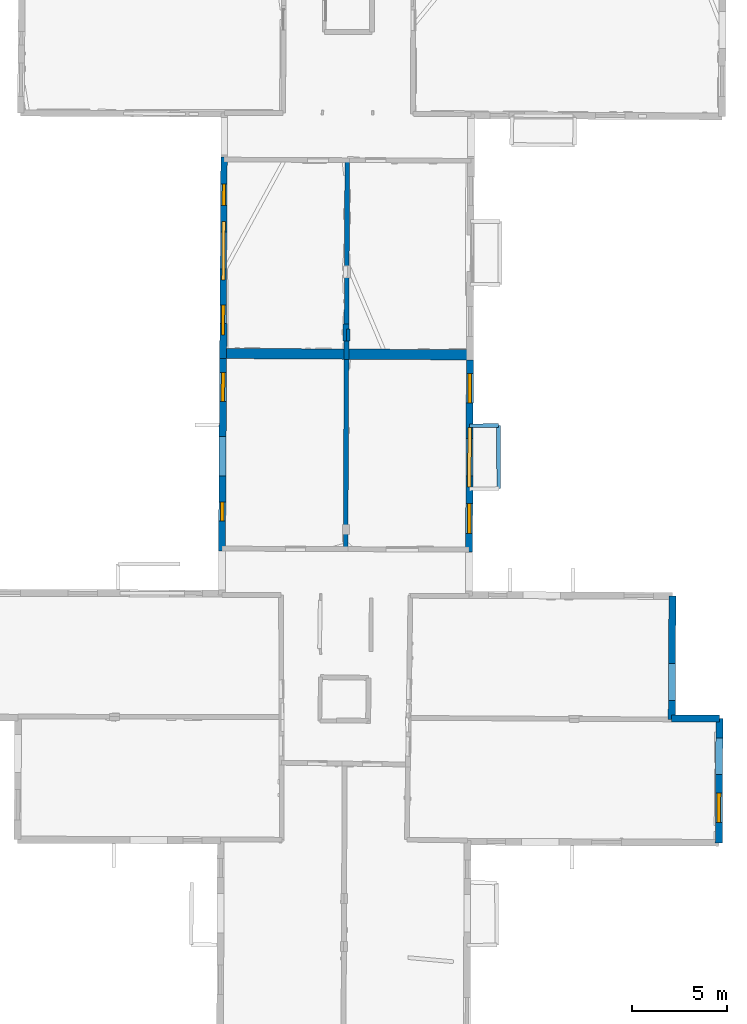
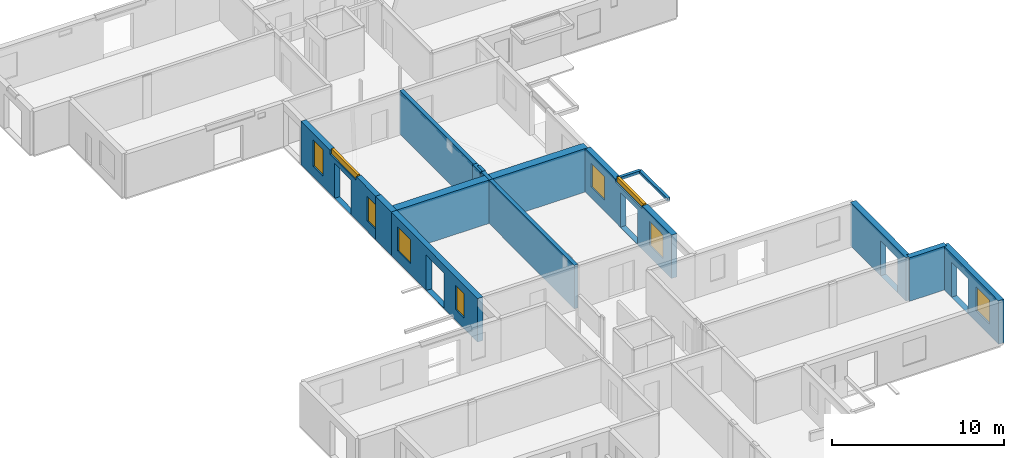
# One storey, part 6 of 15: 15 walls, 9 windows, 14 openings.
"""IFC2X3 building model written with IfcOpenShell, lengths in metres."""

from ifc_helpers import new_model, entity, si_unit, converted_unit, derived_unit, direction, frame, frame_2d, origin, origin_2d_with_axis, place, context, subcontext, project, spatial, polyline, rectangle, outline, extrude, source, transform, mapped, material, layer, layer_set, layer_usage, type_object, type_shapes, element, fill, save


model = new_model("IFC2X3")

# Units and contexts
model_context = context("Model", 3, precision=1e-05, world=origin(), true_north=direction((0.0, 1.0)))
body_context = subcontext(model_context, "Body", "Model", "MODEL_VIEW")
ifc_project = project(units=[si_unit("LENGTHUNIT", "METRE"), si_unit("AREAUNIT", "SQUARE_METRE"), si_unit("VOLUMEUNIT", "CUBIC_METRE"), converted_unit("PLANEANGLEUNIT", "DEGREE", entity("IfcRatioMeasure", 0.0174532925199433), si_unit("PLANEANGLEUNIT", "RADIAN"), dimensions=[0, 0, 0, 0, 0, 0, 0]), si_unit("MASSUNIT", "GRAM", prefix="KILO"), derived_unit("MASSDENSITYUNIT", [(si_unit("MASSUNIT", "GRAM", prefix="KILO"), 1), (si_unit("LENGTHUNIT", "METRE"), -3)]), derived_unit("MOMENTOFINERTIAUNIT", [(si_unit("LENGTHUNIT", "METRE"), 4)]), si_unit("TIMEUNIT", "SECOND"), si_unit("FREQUENCYUNIT", "HERTZ"), si_unit("THERMODYNAMICTEMPERATUREUNIT", "DEGREE_CELSIUS"), derived_unit("THERMALTRANSMITTANCEUNIT", [(si_unit("MASSUNIT", "GRAM", prefix="KILO"), 1), (si_unit("THERMODYNAMICTEMPERATUREUNIT", "KELVIN"), -1), (si_unit("TIMEUNIT", "SECOND"), -3)]), derived_unit("VOLUMETRICFLOWRATEUNIT", [(si_unit("LENGTHUNIT", "METRE"), 3), (si_unit("TIMEUNIT", "SECOND"), -1)]), si_unit("ELECTRICCURRENTUNIT", "AMPERE"), si_unit("ELECTRICVOLTAGEUNIT", "VOLT"), si_unit("POWERUNIT", "WATT"), si_unit("FORCEUNIT", "NEWTON", prefix="KILO"), si_unit("ILLUMINANCEUNIT", "LUX"), si_unit("LUMINOUSFLUXUNIT", "LUMEN"), si_unit("LUMINOUSINTENSITYUNIT", "CANDELA"), derived_unit("USERDEFINED", [(si_unit("MASSUNIT", "GRAM", prefix="KILO"), -1), (si_unit("LENGTHUNIT", "METRE"), -2), (si_unit("TIMEUNIT", "SECOND"), 3), (si_unit("LUMINOUSFLUXUNIT", "LUMEN"), 1)]), derived_unit("LINEARVELOCITYUNIT", [(si_unit("LENGTHUNIT", "METRE"), 1), (si_unit("TIMEUNIT", "SECOND"), -1)]), si_unit("PRESSUREUNIT", "PASCAL"), derived_unit("USERDEFINED", [(si_unit("LENGTHUNIT", "METRE"), -2), (si_unit("MASSUNIT", "GRAM", prefix="KILO"), 1), (si_unit("TIMEUNIT", "SECOND"), -2)]), derived_unit("LINEARFORCEUNIT", [(si_unit("MASSUNIT", "GRAM", prefix="KILO"), 1), (si_unit("LENGTHUNIT", "METRE"), 1), (si_unit("TIMEUNIT", "SECOND"), -2), (si_unit("LENGTHUNIT", "METRE"), -1)]), derived_unit("PLANARFORCEUNIT", [(si_unit("MASSUNIT", "GRAM", prefix="KILO"), 1), (si_unit("LENGTHUNIT", "METRE"), 1), (si_unit("TIMEUNIT", "SECOND"), -2), (si_unit("LENGTHUNIT", "METRE"), -2)])], contexts=[model_context])

# Site, building, storey
placement_1 = place(None, origin())
site = spatial("IfcSite", under=ifc_project, at=placement_1, CompositionType="ELEMENT")
building = spatial("IfcBuilding", under=site, at=placement_1, CompositionType="ELEMENT")
storey_placement = place(placement_1, frame((0.0, 0.0, 2.3807327747345)))
storey = spatial("IfcBuildingStorey", under=building, at=storey_placement, Name="Level 2", CompositionType="ELEMENT", Elevation=2.3807327747345)

# Walls
ifc_material_1 = material(Name="Default wall")
ifc_layer_1 = layer(ifc_material_1, 0.25)
ifc_layer_set_1 = layer_set([ifc_layer_1], Name="wall_thickness_0.2500")
ifc_layer_usage_1 = layer_usage(ifc_layer_set_1, "AXIS2", "POSITIVE", -0.125)
wall_type_1 = type_object("IfcWallType", Name="wall_thickness_0.2500", PredefinedType="STANDARD", material=ifc_layer_set_1)
wall_1_placement = place(storey_placement, frame((6.3156768318917, 48.7543611342191, 0.0), z_axis=(0.0, 0.0, 1.0), x_axis=(-0.00418840502214472, -0.999991228593216, 0.0)))
element("IfcWallStandardCase", 1, at=wall_1_placement, inside=storey, type_object=wall_type_1, material=ifc_layer_usage_1, Name="Wall:763", ObjectType="Wall", context=body_context, shape_type="SweptSolid", body=[
    extrude(outline(polyline([(10.470390607145, -0.125), (10.470390607145, 0.125), (0.0, 0.125), (0.0, -0.125), (10.470390607145, -0.125)])), origin(), (0.0, 0.0, 1.0), 3.08589615821838),
])
wall_2_placement = place(storey_placement, frame((6.27182259528892, 38.2840623671293, 0.0), z_axis=(0.0, 0.0, 1.0), x_axis=(-0.00418836837011911, -0.999991228746731, 0.0)))
element("IfcWallStandardCase", 2, at=wall_2_placement, inside=storey, type_object=wall_type_1, material=ifc_layer_usage_1, Name="Wall:764", ObjectType="Wall", context=body_context, shape_type="SweptSolid", body=[
    extrude(outline(polyline([(9.98389608873726, -0.125), (9.98389608873726, 0.125), (0.0, 0.125), (0.0, -0.125), (9.98389608873726, -0.125)])), origin(), (0.0, 0.0, 1.0), 3.08589615821838),
])
ifc_layer_2 = layer(ifc_material_1, 0.2)
ifc_layer_set_2 = layer_set([ifc_layer_2], Name="wall_thickness_0.2000")
ifc_layer_usage_2 = layer_usage(ifc_layer_set_2, "AXIS2", "POSITIVE", -0.1)
wall_type_2 = type_object("IfcWallType", Name="wall_thickness_0.2000", PredefinedType="STANDARD", material=ifc_layer_set_2)
placement_2 = place(placement_1, frame((0.0, 0.0, 5.26399993896484)))
wall_3_placement = place(placement_2, frame((12.7504581010681, 34.7912910754824, 0.0), z_axis=(0.0, 0.0, 1.0), x_axis=(0.999992666141911, 0.0038298384290755, 0.0)))
element("IfcWallStandardCase", 3, at=wall_3_placement, inside=storey, type_object=wall_type_2, material=ifc_layer_usage_2, Name="Wall:726", ObjectType="Wall", context=body_context, shape_type="SweptSolid", body=[
    extrude(outline(polyline([(1.51000653468389, -0.1), (1.51000653468389, 0.1), (0.0, 0.1), (0.0, -0.1), (1.51000653468389, -0.1)])), origin(), (0.0, 0.0, 1.0), 0.202628993988037),
])
placement_3 = place(placement_1, frame((0.0, 0.0, 5.26399993896484)))
wall_4_placement = place(placement_3, frame((14.2604541777438, 34.7970756808288, 0.0), z_axis=(0.0, 0.0, 1.0), x_axis=(0.00704195733225615, -0.999975205111072, 0.0)))
element("IfcWallStandardCase", 4, at=wall_4_placement, inside=storey, type_object=wall_type_2, material=ifc_layer_usage_2, Name="Wall:737", ObjectType="Wall", context=body_context, shape_type="SweptSolid", body=[
    extrude(outline(polyline([(3.31445138311406, -0.1), (3.31445138311406, 0.1), (0.0, 0.1), (0.0, -0.1), (3.31445138311406, -0.1)])), origin(), (0.0, 0.0, 1.0), 0.202628993988037),
])

# Wall, openings, windows
ifc_layer_3 = layer(ifc_material_1, 0.340000003576279)
ifc_layer_set_3 = layer_set([ifc_layer_3], Name="wall_thickness_0.3400")
ifc_layer_usage_3 = layer_usage(ifc_layer_set_3, "AXIS2", "POSITIVE", -0.170000001788139)
wall_type_3 = type_object("IfcWallType", Name="wall_thickness_0.3400", PredefinedType="STANDARD", material=ifc_layer_set_3)
wall_5_placement = place(storey_placement, frame((-0.161745375972368, 48.9116534915909, 0.0), z_axis=(0.0, 0.0, 1.0), x_axis=(-0.00591294725127191, -0.999982518374598, 0.0)))
wall_5 = element("IfcWallStandardCase", 5, at=wall_5_placement, inside=storey, type_object=wall_type_3, material=ifc_layer_usage_3, Name="Wall:784", ObjectType="Wall", context=body_context, shape_type="SweptSolid", body=[
    extrude(outline(polyline([(8.7541889871596, -0.170000001788139), (8.7541889871596, 0.170000001788139), (0.0, 0.170000001788139), (0.0, -0.170000001788139), (8.7541889871596, -0.170000001788139)])), origin(), (0.0, 0.0, 1.0), 3.08589615821838),
])
opening_1_placement = place(wall_5_placement, frame((3.94108986341754, -0.170000001788139, 0.00526785850524902)))
element("IfcOpeningElement", 6, at=opening_1_placement, cuts=wall_5, Name="Opening : 1935 x 2465 : 494", ObjectType="Opening", context=body_context, shape_type="SweptSolid", body=[
    extrude(rectangle(XDim=1.935, YDim=2.465, at=frame_2d((1.2325, 0.9675), x_axis=(0.0, 1.0))), frame((0.0, 0.0, 0.0), z_axis=(0.0, 1.0, 0.0), x_axis=(0.0, 0.0, 1.0)), (0.0, 0.0, 1.0), 0.340000003576279),
])
opening_2_placement = place(wall_5_placement, frame((1.40608766182194, -0.170000001788139, 0.750267744064331)))
opening_2 = element("IfcOpeningElement", 7, at=opening_2_placement, cuts=wall_5, Name="Opening : 1145 x 1865 : 495", ObjectType="Opening", context=body_context, shape_type="SweptSolid", body=[
    extrude(rectangle(XDim=1.145, YDim=1.865, at=frame_2d((0.9325, 0.5725), x_axis=(0.0, 1.0))), frame((0.0, 0.0, 0.0), z_axis=(0.0, 1.0, 0.0), x_axis=(0.0, 0.0, 1.0)), (0.0, 0.0, 1.0), 0.340000003576279),
])
opening_3_placement = place(wall_5_placement, frame((3.39108864089171, -0.170000001788139, 2.81026768684387)))
opening_3 = element("IfcOpeningElement", 8, at=opening_3_placement, cuts=wall_5, Name="Opening : 3075 x 365 : 496", ObjectType="Opening", context=body_context, shape_type="SweptSolid", body=[
    extrude(rectangle(XDim=3.075, YDim=0.365, at=frame_2d((0.1825, 1.5375), x_axis=(0.0, 1.0))), frame((0.0, 0.0, 0.0), z_axis=(0.0, 1.0, 0.0), x_axis=(0.0, 0.0, 1.0)), (0.0, 0.0, 1.0), 0.340000003576279),
])
opening_4_placement = place(wall_5_placement, frame((7.76608882897656, -0.170000001788139, 0.720267772674561)))
opening_4 = element("IfcOpeningElement", 9, at=opening_4_placement, cuts=wall_5, Name="Opening : 1595 x 1750 : 497", ObjectType="Opening", context=body_context, shape_type="SweptSolid", body=[
    extrude(rectangle(XDim=1.595, YDim=1.75, at=frame_2d((0.875, 0.7975), x_axis=(0.0, 1.0))), frame((0.0, 0.0, 0.0), z_axis=(0.0, 1.0, 0.0), x_axis=(0.0, 0.0, 1.0)), (0.0, 0.0, 1.0), 0.340000003576279),
])
ifc_material_2 = material(Name="Window Default")
window_style_1 = type_object("IfcWindowStyle", Name="Window : 1145 x 1865mm", ConstructionType="NOTDEFINED", OperationType="NOTDEFINED", ParameterTakesPrecedence=False, Sizeable=False, material=ifc_material_2)
shared_shape_1 = source(origin(), body_context, "Body", "SweptSolid", [
    extrude(rectangle(XDim=0.170000001788139, YDim=1.145, at=origin_2d_with_axis()), frame((0.5725, 0.170000001788139, 0.0), z_axis=(0.0, 0.0, 1.0), x_axis=(0.0, 1.0, 0.0)), (0.0, 0.0, 1.0), 1.865),
])
type_shapes(window_style_1, [shared_shape_1])
window_1_placement = place(opening_2_placement, origin())
window_1 = element("IfcWindow", 10, at=window_1_placement, inside=storey, type_object=window_style_1, Name="Window : 1145 x 1865mm : 265", ObjectType="Window : 1145 x 1865mm", OverallHeight=1.865, OverallWidth=1.145, context=body_context, shape_type="MappedRepresentation", body=[
    mapped(shared_shape_1, transform((0.0, 0.0, 0.0), scale=1.0)),
])
fill(opening_2, window_1)
window_style_2 = type_object("IfcWindowStyle", Name="Window : 3075 x 365mm", ConstructionType="NOTDEFINED", OperationType="NOTDEFINED", ParameterTakesPrecedence=False, Sizeable=False, material=ifc_material_2)
shared_shape_2 = source(origin(), body_context, "Body", "SweptSolid", [
    extrude(rectangle(XDim=0.170000001788139, YDim=3.075, at=origin_2d_with_axis()), frame((1.5375, 0.170000001788139, 0.0), z_axis=(0.0, 0.0, 1.0), x_axis=(0.0, 1.0, 0.0)), (0.0, 0.0, 1.0), 0.365),
])
type_shapes(window_style_2, [shared_shape_2])
window_2_placement = place(opening_3_placement, origin())
window_2 = element("IfcWindow", 11, at=window_2_placement, inside=storey, type_object=window_style_2, Name="Window : 3075 x 365mm : 266", ObjectType="Window : 3075 x 365mm", OverallHeight=0.365, OverallWidth=3.075, context=body_context, shape_type="MappedRepresentation", body=[
    mapped(shared_shape_2, transform((0.0, 0.0, 0.0), scale=1.0)),
])
fill(opening_3, window_2)
window_style_3 = type_object("IfcWindowStyle", Name="Window : 1595 x 1750mm", ConstructionType="NOTDEFINED", OperationType="NOTDEFINED", ParameterTakesPrecedence=False, Sizeable=False, material=ifc_material_2)
shared_shape_3 = source(origin(), body_context, "Body", "SweptSolid", [
    extrude(rectangle(XDim=0.170000001788139, YDim=1.595, at=origin_2d_with_axis()), frame((0.7975, 0.170000001788139, 0.0), z_axis=(0.0, 0.0, 1.0), x_axis=(0.0, 1.0, 0.0)), (0.0, 0.0, 1.0), 1.75),
])
type_shapes(window_style_3, [shared_shape_3])
window_3_placement = place(opening_4_placement, origin())
window_3 = element("IfcWindow", 12, at=window_3_placement, inside=storey, type_object=window_style_3, Name="Window : 1595 x 1750mm : 267", ObjectType="Window : 1595 x 1750mm", OverallHeight=1.75, OverallWidth=1.595, context=body_context, shape_type="MappedRepresentation", body=[
    mapped(shared_shape_3, transform((0.0, 0.0, 0.0), scale=1.0)),
])
fill(opening_4, window_3)

# Wall, opening
ifc_layer_4 = layer(ifc_material_1, 0.370000004768372)
ifc_layer_set_4 = layer_set([ifc_layer_4], Name="wall_thickness_0.3700")
ifc_layer_usage_4 = layer_usage(ifc_layer_set_4, "AXIS2", "POSITIVE", -0.185000002384186)
wall_type_4 = type_object("IfcWallType", Name="wall_thickness_0.3700", PredefinedType="STANDARD", material=ifc_layer_set_4)
wall_6_placement = place(storey_placement, frame((23.4122642862826, 25.841536161951, 0.0), z_axis=(0.0, 0.0, 1.0), x_axis=(-0.00556036745275853, -0.999984541037405, 0.0)))
wall_6 = element("IfcWallStandardCase", 13, at=wall_6_placement, inside=storey, type_object=wall_type_4, material=ifc_layer_usage_4, Name="Wall:707", ObjectType="Wall", context=body_context, shape_type="SweptSolid", body=[
    extrude(outline(polyline([(6.49484756547081, -0.185000002384186), (6.49484756547081, 0.185000002384186), (0.0, 0.185000002384186), (0.0, -0.185000002384186), (6.49484756547081, -0.185000002384186)])), origin(), (0.0, 0.0, 1.0), 3.08589615821838),
])
opening_5_placement = place(wall_6_placement, frame((3.54695462286384, -0.185000002384186, 0.00526785850524902)))
element("IfcOpeningElement", 14, at=opening_5_placement, cuts=wall_6, Name="Opening : 1955 x 2465 : 448", ObjectType="Opening", context=body_context, shape_type="SweptSolid", body=[
    extrude(rectangle(XDim=1.955, YDim=2.465, at=frame_2d((1.2325, 0.9775), x_axis=(0.0, 1.0))), frame((0.0, 0.0, 0.0), z_axis=(0.0, 1.0, 0.0), x_axis=(0.0, 0.0, 1.0)), (0.0, 0.0, 1.0), 0.370000004768372),
])

# Wall, openings, window
wall_7_placement = place(storey_placement, frame((25.8828886507864, 19.4024328590418, 0.0), z_axis=(0.0, 0.0, 1.0), x_axis=(-0.00498765009158397, -0.999987561595925, 0.0)))
wall_7 = element("IfcWallStandardCase", 15, at=wall_7_placement, inside=storey, type_object=wall_type_4, material=ifc_layer_usage_4, Name="Wall:765", ObjectType="Wall", context=body_context, shape_type="SweptSolid", body=[
    extrude(outline(polyline([(6.54502045074674, -0.185000002384186), (6.54502045074674, 0.185000002384186), (0.0, 0.185000002384186), (0.0, -0.185000002384186), (6.54502045074674, -0.185000002384186)])), origin(), (0.0, 0.0, 1.0), 3.08589615821838),
])
opening_6_placement = place(wall_7_placement, frame((1.03396929571439, -0.185000002384186, 0.00526785850524902)))
element("IfcOpeningElement", 16, at=opening_6_placement, cuts=wall_7, Name="Opening : 1925 x 2480 : 484", ObjectType="Opening", context=body_context, shape_type="SweptSolid", body=[
    extrude(rectangle(XDim=1.925, YDim=2.48, at=frame_2d((1.24, 0.9625), x_axis=(0.0, 1.0))), frame((0.0, 0.0, 0.0), z_axis=(0.0, 1.0, 0.0), x_axis=(0.0, 0.0, 1.0)), (0.0, 0.0, 1.0), 0.370000004768372),
])
opening_7_placement = place(wall_7_placement, frame((3.92896951994931, -0.185000002384186, 0.790267705917358)))
opening_7 = element("IfcOpeningElement", 17, at=opening_7_placement, cuts=wall_7, Name="Opening : 1545 x 1695 : 485", ObjectType="Opening", context=body_context, shape_type="SweptSolid", body=[
    extrude(rectangle(XDim=1.545, YDim=1.695, at=frame_2d((0.8475, 0.7725), x_axis=(0.0, 1.0))), frame((0.0, 0.0, 0.0), z_axis=(0.0, 1.0, 0.0), x_axis=(0.0, 0.0, 1.0)), (0.0, 0.0, 1.0), 0.370000004768372),
])
window_style_4 = type_object("IfcWindowStyle", Name="Window : 1545 x 1695mm", ConstructionType="NOTDEFINED", OperationType="NOTDEFINED", ParameterTakesPrecedence=False, Sizeable=False, material=ifc_material_2)
shared_shape_4 = source(origin(), body_context, "Body", "SweptSolid", [
    extrude(rectangle(XDim=0.185000002384186, YDim=1.545, at=origin_2d_with_axis()), frame((0.7725, 0.185000002384186, 0.0), z_axis=(0.0, 0.0, 1.0), x_axis=(0.0, 1.0, 0.0)), (0.0, 0.0, 1.0), 1.695),
])
type_shapes(window_style_4, [shared_shape_4])
window_4_placement = place(opening_7_placement, origin())
window_4 = element("IfcWindow", 18, at=window_4_placement, inside=storey, type_object=window_style_4, Name="Window : 1545 x 1695mm : 261", ObjectType="Window : 1545 x 1695mm", OverallHeight=1.695, OverallWidth=1.545, context=body_context, shape_type="MappedRepresentation", body=[
    mapped(shared_shape_4, transform((0.0, 0.0, 0.0), scale=1.0)),
])
fill(opening_7, window_4)

# Wall
wall_8_placement = place(storey_placement, frame((-0.198508576094938, 40.1575288485552, 0.0), z_axis=(0.0, 0.0, 1.0), x_axis=(-0.00591293372574429, -0.999982518454575, 0.0)))
element("IfcWallStandardCase", 19, at=wall_8_placement, inside=storey, type_object=wall_type_4, material=ifc_layer_usage_4, Name="Wall:785", ObjectType="Wall", context=body_context, shape_type="SweptSolid", body=[
    extrude(outline(polyline([(1.83664099404172, -0.185000002384186), (1.83664099404172, 0.185000002384186), (0.0, 0.185000002384186), (0.0, -0.185000002384186), (1.83664099404172, -0.185000002384186)])), origin(), (0.0, 0.0, 1.0), 3.08589615821838),
])

# Wall, openings, windows
wall_9_placement = place(storey_placement, frame((-0.209368512570692, 38.3209199618365, 0.0), z_axis=(0.0, 0.0, 1.0), x_axis=(-0.00591293733645481, -0.999982518433225, 0.0)))
wall_9 = element("IfcWallStandardCase", 20, at=wall_9_placement, inside=storey, type_object=wall_type_4, material=ifc_layer_usage_4, Name="Wall:786", ObjectType="Wall", context=body_context, shape_type="SweptSolid", body=[
    extrude(outline(polyline([(10.1209769488449, -0.185000002384186), (10.1209769488449, 0.185000002384186), (0.0, 0.185000002384186), (0.0, -0.185000002384186), (10.1209769488449, -0.185000002384186)])), origin(), (0.0, 0.0, 1.0), 3.08589615821838),
])
opening_8_placement = place(wall_9_placement, frame((4.10435031508724, -0.185000002384186, 0.00526785850524902)))
element("IfcOpeningElement", 21, at=opening_8_placement, cuts=wall_9, Name="Opening : 2065 x 2510 : 498", ObjectType="Opening", context=body_context, shape_type="SweptSolid", body=[
    extrude(rectangle(XDim=2.065, YDim=2.51, at=frame_2d((1.255, 1.0325), x_axis=(0.0, 1.0))), frame((0.0, 0.0, 0.0), z_axis=(0.0, 1.0, 0.0), x_axis=(0.0, 0.0, 1.0)), (0.0, 0.0, 1.0), 0.370000004768372),
])
opening_9_placement = place(wall_9_placement, frame((0.725259108347929, -0.185000002384186, 0.770267724990845)))
opening_9 = element("IfcOpeningElement", 22, at=opening_9_placement, cuts=wall_9, Name="Opening : 1540 x 1700 : 499", ObjectType="Opening", context=body_context, shape_type="SweptSolid", body=[
    extrude(rectangle(XDim=1.54, YDim=1.7, at=frame_2d((0.85, 0.77), x_axis=(0.0, 1.0))), frame((0.0, 0.0, 0.0), z_axis=(0.0, 1.0, 0.0), x_axis=(0.0, 0.0, 1.0)), (0.0, 0.0, 1.0), 0.370000004768372),
])
opening_10_placement = place(wall_9_placement, frame((7.55063477419573, -0.185000002384186, 0.755267858505249)))
opening_10 = element("IfcOpeningElement", 23, at=opening_10_placement, cuts=wall_9, Name="Opening : 995 x 1730 : 500", ObjectType="Opening", context=body_context, shape_type="SweptSolid", body=[
    extrude(rectangle(XDim=0.995, YDim=1.73, at=frame_2d((0.865, 0.4975), x_axis=(0.0, 1.0))), frame((0.0, 0.0, 0.0), z_axis=(0.0, 1.0, 0.0), x_axis=(0.0, 0.0, 1.0)), (0.0, 0.0, 1.0), 0.370000004768372),
])
window_style_5 = type_object("IfcWindowStyle", Name="Window : 1540 x 1700mm", ConstructionType="NOTDEFINED", OperationType="NOTDEFINED", ParameterTakesPrecedence=False, Sizeable=False, material=ifc_material_2)
shared_shape_5 = source(origin(), body_context, "Body", "SweptSolid", [
    extrude(rectangle(XDim=0.185000002384186, YDim=1.54, at=origin_2d_with_axis()), frame((0.77, 0.185000002384186, 0.0), z_axis=(0.0, 0.0, 1.0), x_axis=(0.0, 1.0, 0.0)), (0.0, 0.0, 1.0), 1.7),
])
type_shapes(window_style_5, [shared_shape_5])
window_5_placement = place(opening_9_placement, origin())
window_5 = element("IfcWindow", 24, at=window_5_placement, inside=storey, type_object=window_style_5, Name="Window : 1540 x 1700mm : 268", ObjectType="Window : 1540 x 1700mm", OverallHeight=1.7, OverallWidth=1.54, context=body_context, shape_type="MappedRepresentation", body=[
    mapped(shared_shape_5, transform((0.0, 0.0, 0.0), scale=1.0)),
])
fill(opening_9, window_5)
window_style_6 = type_object("IfcWindowStyle", Name="Window : 995 x 1730mm", ConstructionType="NOTDEFINED", OperationType="NOTDEFINED", ParameterTakesPrecedence=False, Sizeable=False, material=ifc_material_2)
shared_shape_6 = source(origin(), body_context, "Body", "SweptSolid", [
    extrude(rectangle(XDim=0.185000002384186, YDim=0.995, at=origin_2d_with_axis()), frame((0.4975, 0.185000002384186, 0.0), z_axis=(0.0, 0.0, 1.0), x_axis=(0.0, 1.0, 0.0)), (0.0, 0.0, 1.0), 1.73),
])
type_shapes(window_style_6, [shared_shape_6])
window_6_placement = place(opening_10_placement, origin())
window_6 = element("IfcWindow", 25, at=window_6_placement, inside=storey, type_object=window_style_6, Name="Window : 995 x 1730mm : 269", ObjectType="Window : 995 x 1730mm", OverallHeight=1.73, OverallWidth=0.995, context=body_context, shape_type="MappedRepresentation", body=[
    mapped(shared_shape_6, transform((0.0, 0.0, 0.0), scale=1.0)),
])
fill(opening_10, window_6)

wall_10_placement = place(storey_placement, frame((12.7657836383905, 38.2475014984775, 0.0), z_axis=(0.0, 0.0, 1.0), x_axis=(-0.00443389533953228, -0.999990170237747, 0.0)))
wall_10 = element("IfcWallStandardCase", 26, at=wall_10_placement, inside=storey, type_object=wall_type_4, material=ifc_layer_usage_4, Name="Wall:799", ObjectType="Wall", context=body_context, shape_type="SweptSolid", body=[
    extrude(outline(polyline([(10.1071645518303, -0.185000002384186), (10.1071645518303, 0.185000002384186), (0.0, 0.185000002384186), (0.0, -0.185000002384186), (10.1071645518303, -0.185000002384186)])), origin(), (0.0, 0.0, 1.0), 3.08589615821838),
])
opening_11_placement = place(wall_10_placement, frame((4.11899802123229, -0.185000002384186, 0.00526785850524902)))
element("IfcOpeningElement", 27, at=opening_11_placement, cuts=wall_10, Name="Opening : 1985 x 2465 : 507", ObjectType="Opening", context=body_context, shape_type="SweptSolid", body=[
    extrude(rectangle(XDim=1.985, YDim=2.465, at=frame_2d((1.2325, 0.9925), x_axis=(0.0, 1.0))), frame((0.0, 0.0, 0.0), z_axis=(0.0, 1.0, 0.0), x_axis=(0.0, 0.0, 1.0)), (0.0, 0.0, 1.0), 0.370000004768372),
])
opening_12_placement = place(wall_10_placement, frame((0.698996750081038, -0.185000002384186, 0.78526759147644)))
opening_12 = element("IfcOpeningElement", 28, at=opening_12_placement, cuts=wall_10, Name="Opening : 1575 x 1685 : 508", ObjectType="Opening", context=body_context, shape_type="SweptSolid", body=[
    extrude(rectangle(XDim=1.575, YDim=1.685, at=frame_2d((0.8425, 0.7875), x_axis=(0.0, 1.0))), frame((0.0, 0.0, 0.0), z_axis=(0.0, 1.0, 0.0), x_axis=(0.0, 0.0, 1.0)), (0.0, 0.0, 1.0), 0.370000004768372),
])
opening_13_placement = place(wall_10_placement, frame((3.55471863811812, -0.185000002384186, 2.87026762962341)))
opening_13 = element("IfcOpeningElement", 29, at=opening_13_placement, cuts=wall_10, Name="Opening : 3120 x 305 : 509", ObjectType="Opening", context=body_context, shape_type="SweptSolid", body=[
    extrude(rectangle(XDim=3.12, YDim=0.305, at=frame_2d((0.1525, 1.56), x_axis=(0.0, 1.0))), frame((0.0, 0.0, 0.0), z_axis=(0.0, 1.0, 0.0), x_axis=(0.0, 0.0, 1.0)), (0.0, 0.0, 1.0), 0.370000004768372),
])
opening_14_placement = place(wall_10_placement, frame((7.54899771014626, -0.185000002384186, 0.795267820358276)))
opening_14 = element("IfcOpeningElement", 30, at=opening_14_placement, cuts=wall_10, Name="Opening : 1575 x 1700 : 510", ObjectType="Opening", context=body_context, shape_type="SweptSolid", body=[
    extrude(rectangle(XDim=1.575, YDim=1.7, at=frame_2d((0.85, 0.7875), x_axis=(0.0, 1.0))), frame((0.0, 0.0, 0.0), z_axis=(0.0, 1.0, 0.0), x_axis=(0.0, 0.0, 1.0)), (0.0, 0.0, 1.0), 0.370000004768372),
])
window_style_7 = type_object("IfcWindowStyle", Name="Window : 1575 x 1700mm", ConstructionType="NOTDEFINED", OperationType="NOTDEFINED", ParameterTakesPrecedence=False, Sizeable=False, material=ifc_material_2)
shared_shape_7 = source(origin(), body_context, "Body", "SweptSolid", [
    extrude(rectangle(XDim=0.189999997615814, YDim=1.575, at=origin_2d_with_axis()), frame((0.7875, 0.189999997615814, 0.0), z_axis=(0.0, 0.0, 1.0), x_axis=(0.0, 1.0, 0.0)), (0.0, 0.0, 1.0), 1.7),
])
type_shapes(window_style_7, [shared_shape_7])
window_7_placement = place(opening_14_placement, origin())
window_7 = element("IfcWindow", 31, at=window_7_placement, inside=storey, type_object=window_style_7, Name="Window : 1575 x 1700mm : 275", ObjectType="Window : 1575 x 1700mm", OverallHeight=1.7, OverallWidth=1.575, context=body_context, shape_type="MappedRepresentation", body=[
    mapped(shared_shape_7, transform((0.0, 0.0, 0.0), scale=1.0)),
])
fill(opening_14, window_7)
window_style_8 = type_object("IfcWindowStyle", Name="Window : 1575 x 1685mm", ConstructionType="NOTDEFINED", OperationType="NOTDEFINED", ParameterTakesPrecedence=False, Sizeable=False, material=ifc_material_2)
shared_shape_8 = source(origin(), body_context, "Body", "SweptSolid", [
    extrude(rectangle(XDim=0.185000002384186, YDim=1.575, at=origin_2d_with_axis()), frame((0.7875, 0.185000002384186, 0.0), z_axis=(0.0, 0.0, 1.0), x_axis=(0.0, 1.0, 0.0)), (0.0, 0.0, 1.0), 1.685),
])
type_shapes(window_style_8, [shared_shape_8])
window_8_placement = place(opening_12_placement, origin())
window_8 = element("IfcWindow", 32, at=window_8_placement, inside=storey, type_object=window_style_8, Name="Window : 1575 x 1685mm : 273", ObjectType="Window : 1575 x 1685mm", OverallHeight=1.685, OverallWidth=1.575, context=body_context, shape_type="MappedRepresentation", body=[
    mapped(shared_shape_8, transform((0.0, 0.0, 0.0), scale=1.0)),
])
fill(opening_12, window_8)
window_style_9 = type_object("IfcWindowStyle", Name="Window : 3120 x 305mm", ConstructionType="NOTDEFINED", OperationType="NOTDEFINED", ParameterTakesPrecedence=False, Sizeable=False, material=ifc_material_2)
shared_shape_9 = source(origin(), body_context, "Body", "SweptSolid", [
    extrude(rectangle(XDim=0.185000002384186, YDim=3.12, at=origin_2d_with_axis()), frame((1.56, 0.185000002384186, 0.0), z_axis=(0.0, 0.0, 1.0), x_axis=(0.0, 1.0, 0.0)), (0.0, 0.0, 1.0), 0.305),
])
type_shapes(window_style_9, [shared_shape_9])
window_9_placement = place(opening_13_placement, origin())
window_9 = element("IfcWindow", 33, at=window_9_placement, inside=storey, type_object=window_style_9, Name="Window : 3120 x 305mm : 274", ObjectType="Window : 3120 x 305mm", OverallHeight=0.305, OverallWidth=3.12, context=body_context, shape_type="MappedRepresentation", body=[
    mapped(shared_shape_9, transform((0.0, 0.0, 0.0), scale=1.0)),
])
fill(opening_13, window_9)

# Walls
wall_11_placement = place(storey_placement, frame((23.3764713345489, 19.4047236618304, 0.0), z_axis=(0.0, 0.0, 1.0), x_axis=(0.999999581658364, -0.000914703830003024, 0.0)))
element("IfcWallStandardCase", 34, at=wall_11_placement, inside=storey, type_object=wall_type_4, material=ifc_layer_usage_4, Name="Wall:810", ObjectType="Wall", context=body_context, shape_type="SweptSolid", body=[
    extrude(outline(polyline([(2.50642118403838, -0.185000002384186), (2.50642118403838, 0.185000002384186), (0.0, 0.185000002384186), (0.0, -0.185000002384186), (2.50642118403838, -0.185000002384186)])), origin(), (0.0, 0.0, 1.0), 3.08589615821838),
])
ifc_layer_5 = layer(ifc_material_1, 0.200000002980232)
ifc_layer_set_5 = layer_set([ifc_layer_5], Name="wall_thickness_0.2000")
ifc_layer_usage_5 = layer_usage(ifc_layer_set_5, "AXIS2", "POSITIVE", -0.100000001490116)
wall_type_5 = type_object("IfcWallType", Name="wall_thickness_0.2000", PredefinedType="STANDARD", material=ifc_layer_set_5)
wall_12_placement = place(storey_placement, frame((6.37025254338135, 39.8731516147445, 0.0), z_axis=(0.0, 0.0, 1.0), x_axis=(0.00318691649093974, -0.999994921768746, 0.0)))
element("IfcWallStandardCase", 35, at=wall_12_placement, inside=storey, type_object=wall_type_5, material=ifc_layer_usage_5, Name="Wall:774", ObjectType="Wall", context=body_context, shape_type="SweptSolid", body=[
    extrude(outline(polyline([(0.635001546217902, -0.100000001490116), (0.635001546217902, 0.100000001490116), (0.0, 0.100000001490116), (0.0, -0.100000001490116), (0.635001546217902, -0.100000001490116)])), origin(), (0.0, 0.0, 1.0), 3.08589615821838),
])
ifc_layer_6 = layer(ifc_material_1, 0.540000021457672)
ifc_layer_set_6 = layer_set([ifc_layer_6], Name="wall_thickness_0.5400")
ifc_layer_usage_6 = layer_usage(ifc_layer_set_6, "AXIS2", "POSITIVE", -0.270000010728836)
wall_type_6 = type_object("IfcWallType", Name="wall_thickness_0.5400", PredefinedType="STANDARD", material=ifc_layer_set_6)
wall_13_placement = place(storey_placement, frame((-0.207773928809177, 38.590914726472, 0.0), z_axis=(0.0, 0.0, 1.0), x_axis=(0.999983991525824, -0.00565832944255788, 0.0)))
element("IfcWallStandardCase", 36, at=wall_13_placement, inside=storey, type_object=wall_type_6, material=ifc_layer_usage_6, Name="Wall:780", ObjectType="Wall", context=body_context, shape_type="SweptSolid", body=[
    extrude(outline(polyline([(6.60622872622302, -0.270000010728836), (6.60622872622302, 0.270000010728836), (0.0, 0.270000010728836), (0.0, -0.270000010728836), (6.60622872622302, -0.270000010728836)])), origin(), (0.0, 0.0, 1.0), 3.08589615821838),
])
wall_14_placement = place(storey_placement, frame((6.39834904177188, 38.5535345079662, 0.0), z_axis=(0.0, 0.0, 1.0), x_axis=(0.999983990587147, -0.00565849533041731, 0.0)))
element("IfcWallStandardCase", 37, at=wall_14_placement, inside=storey, type_object=wall_type_6, material=ifc_layer_usage_6, Name="Wall:781", ObjectType="Wall", context=body_context, shape_type="SweptSolid", body=[
    extrude(outline(polyline([(6.36873284575136, -0.270000010728836), (6.36873284575136, 0.270000010728836), (0.0, 0.270000010728836), (0.0, -0.270000010728836), (6.36873284575136, -0.270000010728836)])), origin(), (0.0, 0.0, 1.0), 3.08589615821838),
])
ifc_layer_7 = layer(ifc_material_1, 0.300000011920929)
ifc_layer_set_7 = layer_set([ifc_layer_7], Name="wall_thickness_0.3000")
ifc_layer_usage_7 = layer_usage(ifc_layer_set_7, "AXIS2", "POSITIVE", -0.150000005960464)
wall_type_7 = type_object("IfcWallType", Name="wall_thickness_0.3000", PredefinedType="STANDARD", material=ifc_layer_set_7)
wall_15_placement = place(storey_placement, frame((6.25454470959653, 40.1277110938728, 0.0), z_axis=(0.0, 0.0, 1.0), x_axis=(-0.00418837186034054, -0.999991228732112, 0.0)))
element("IfcWallStandardCase", 38, at=wall_15_placement, inside=storey, type_object=wall_type_7, material=ifc_layer_usage_7, Name="Wall:762", ObjectType="Wall", context=body_context, shape_type="SweptSolid", body=[
    extrude(outline(polyline([(0.888240975814001, -0.150000005960464), (0.888240975814001, 0.150000005960464), (0.0, 0.150000005960464), (0.0, -0.150000005960464), (0.888240975814001, -0.150000005960464)])), origin(), (0.0, 0.0, 1.0), 3.08589615821838),
])

save(model, "model.ifc")
